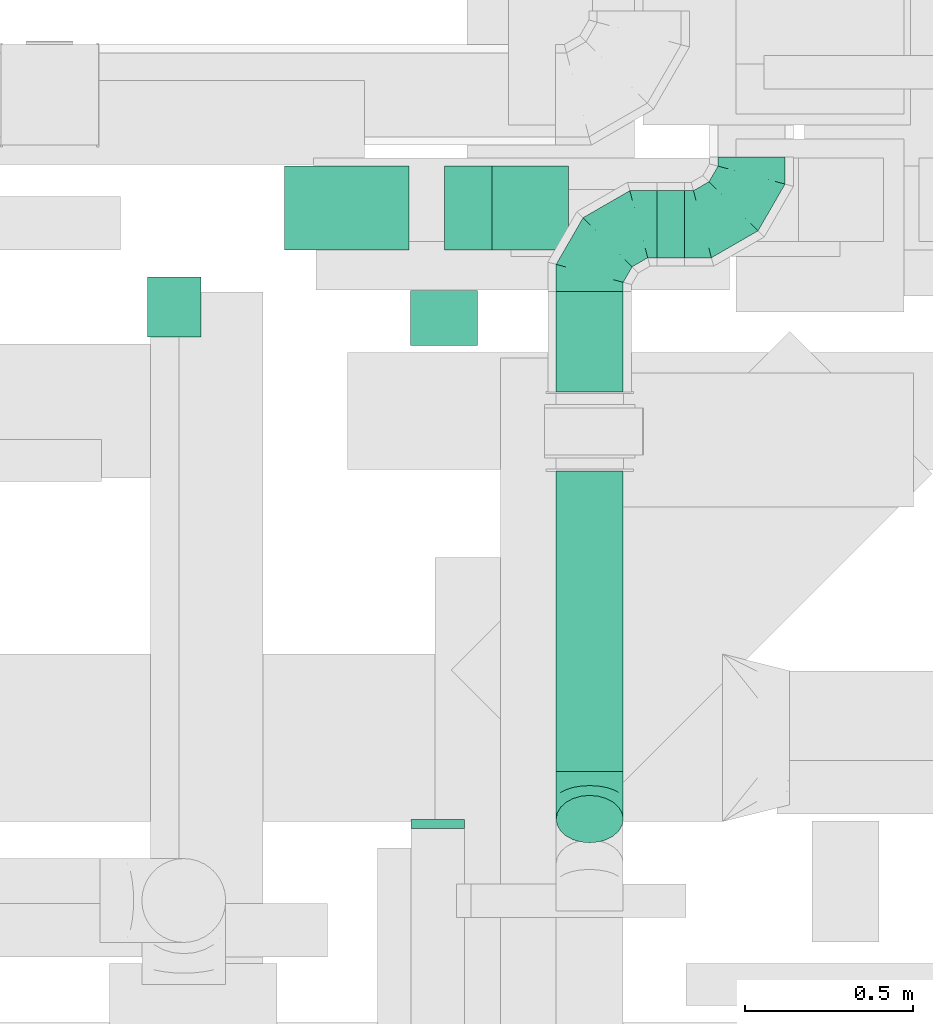
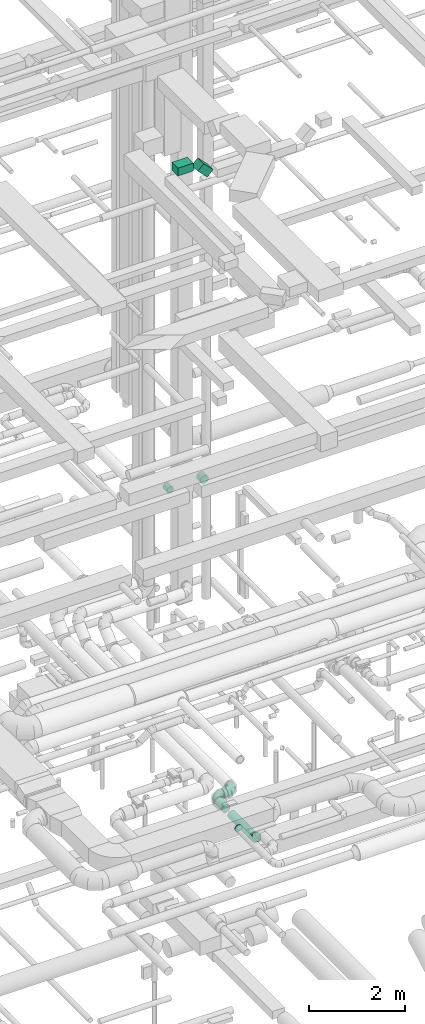
# One storey, part 165 of 337: 7 flow segments, 4 flow fittings.
"""IFC2X3 building model written with IfcOpenShell, lengths in millimetres."""

import ifcopenshell
import ifcopenshell.guid

model = None  # the IFC model being written
_history = None  # IfcOwnerHistory: only IFC2X3 demands one
_inside = {}  # id of a spatial element -> (the spatial element, [elements in it])
_under = {}  # id of a project, library or spatial element -> (it, [spatial elements below it])
_declared = {}  # id of a project -> (the project, [libraries it declares])
_typed = {}  # id of a type object -> (the type object, [elements of that type])
_made_of = {}  # id of a material, layer set ... -> (it, [elements and type objects made of it])


def new_model(schema):
    """Start an empty IFC model of exactly this schema.

    Asked for "IFC4X3", IfcOpenShell would pick the latest addendum, in which some entities
    have other attributes; the version numbers below select the first issue.
    IFC2X3 requires an IfcOwnerHistory on every rooted entity: one is made here for all.
    """
    global model, _history
    if schema == "IFC4X3":
        model = ifcopenshell.file(schema_version=(4, 3, 0, 0))
    else:
        model = ifcopenshell.file(schema=schema)
    _inside.clear()
    _under.clear()
    _declared.clear()
    _typed.clear()
    _made_of.clear()
    _history = None
    if model.schema == "IFC2X3":
        org = make("IfcOrganization", Name="unknown")
        user = make(
            "IfcPersonAndOrganization",
            ThePerson=make("IfcPerson", FamilyName="unknown"),
            TheOrganization=org,
        )
        app = make(
            "IfcApplication",
            ApplicationDeveloper=org,
            Version="unknown",
            ApplicationFullName="unknown",
            ApplicationIdentifier="unknown",
        )
        _history = make(
            "IfcOwnerHistory",
            OwningUser=user,
            OwningApplication=app,
            ChangeAction="ADDED",
            CreationDate=0,
        )
    return model


def make(cls, **values):
    """One entity of the class cls with the attributes given. An attribute that is None is left unset."""
    return model.create_entity(
        cls, **{name: value for name, value in values.items() if value is not None}
    )


def entity(cls, *values):
    """Any entity or typed value of the class cls, its attributes in the order of the schema. None: left unset."""
    e = model.create_entity(cls)
    for i, value in enumerate(values):
        if value is not None:
            e[i] = value
    return e


def rooted(cls, **values):
    """An entity with a GlobalId (a new one), such as an element, a storey or a relation."""
    return make(cls, GlobalId=ifcopenshell.guid.new(), OwnerHistory=_history, **values)


def si_unit(unit_type, name, prefix=None):
    """IfcSIUnit, for example si_unit("LENGTHUNIT", "METRE", prefix="MILLI")."""
    return make("IfcSIUnit", UnitType=unit_type, Prefix=prefix, Name=name)


def converted_unit(unit_type, name, factor, base, dimensions=None, offset=None):
    """IfcConversionBasedUnit, such as the inch: factor (a typed value) times the base unit."""
    return make(
        "IfcConversionBasedUnit"
        if offset is None
        else "IfcConversionBasedUnitWithOffset",
        ConversionOffset=offset,
        Dimensions=None
        if dimensions is None
        else entity("IfcDimensionalExponents", *dimensions),
        UnitType=unit_type,
        Name=name,
        ConversionFactor=make(
            "IfcMeasureWithUnit", ValueComponent=factor, UnitComponent=base
        ),
    )


def derived_unit(unit_type, elements):
    """IfcDerivedUnit: a product of units, each with its exponent."""
    return make(
        "IfcDerivedUnit",
        Elements=[
            make("IfcDerivedUnitElement", Unit=unit, Exponent=power)
            for unit, power in elements
        ],
        UnitType=unit_type,
    )


def assignment(units):
    """IfcUnitAssignment: the units of a project."""
    return None if units is None else make("IfcUnitAssignment", Units=units)


def point(xyz):
    """IfcCartesianPoint."""
    return None if xyz is None else make("IfcCartesianPoint", Coordinates=xyz)


def direction(xyz):
    """IfcDirection."""
    return None if xyz is None else make("IfcDirection", DirectionRatios=xyz)


def frame(location, z_axis=None, x_axis=None):
    """IfcAxis2Placement3D, a coordinate frame: its origin and axes. An axis left out is left unset."""
    return make(
        "IfcAxis2Placement3D",
        Location=point(location),
        Axis=direction(z_axis),
        RefDirection=direction(x_axis),
    )


def frame_2d(location, x_axis=None):
    """IfcAxis2Placement2D, a coordinate frame in the plane: its origin and x axis."""
    return make(
        "IfcAxis2Placement2D", Location=point(location), RefDirection=direction(x_axis)
    )


def origin():
    """The frame at (0, 0, 0) with its axes left unset."""
    return frame((0.0, 0.0, 0.0))


def origin_2d_with_axis():
    """The frame at (0, 0) in the plane with the x axis (1, 0) written out."""
    return frame_2d((0.0, 0.0), x_axis=(1.0, 0.0))


def place(relative_to, where):
    """IfcLocalPlacement: puts the frame where relative to a parent placement (None: the world)."""
    return make(
        "IfcLocalPlacement", PlacementRelTo=relative_to, RelativePlacement=where
    )


def context(
    kind, dimensions, precision=None, world=None, true_north=None, identifier=None
):
    """IfcGeometricRepresentationContext, for example the 3D "Model" context."""
    return make(
        "IfcGeometricRepresentationContext",
        ContextIdentifier=identifier,
        ContextType=kind,
        CoordinateSpaceDimension=dimensions,
        Precision=precision,
        WorldCoordinateSystem=world,
        TrueNorth=true_north,
    )


def subcontext(parent, identifier, kind, view, scale=None):
    """IfcGeometricRepresentationSubContext, for example "Body" below "Model"."""
    return make(
        "IfcGeometricRepresentationSubContext",
        ContextIdentifier=identifier,
        ContextType=kind,
        ParentContext=parent,
        TargetScale=scale,
        TargetView=view,
    )


def project(units=None, contexts=None):
    """IfcProject with its units and contexts."""
    return rooted(
        "IfcProject",
        Name="project",
        RepresentationContexts=contexts,
        UnitsInContext=assignment(units),
    )


def spatial(cls, under=None, at=None, **own):
    """A site, building, storey or space (cls), placed at a placement, below another one or the project."""
    s = rooted(cls, ObjectPlacement=at, **own)
    if under is not None:
        _under.setdefault(under.id(), (under, []))[1].append(s)
    return s


def profile(cls, at=None, kind="AREA", **sizes):
    """A parametric profile (cls). Its sizes go by their IFC names, for example OverallWidth=200.0."""
    return make(cls, ProfileType=kind, Position=at, **sizes)


def rectangle(**sizes):
    """IfcRectangleProfileDef."""
    return profile("IfcRectangleProfileDef", **sizes)


def circle(**sizes):
    """IfcCircleProfileDef."""
    return profile("IfcCircleProfileDef", **sizes)


def extrude(swept, where, along, depth):
    """IfcExtrudedAreaSolid: the profile swept, set in the frame where, extruded along a direction by depth."""
    return make(
        "IfcExtrudedAreaSolid",
        SweptArea=swept,
        Position=where,
        ExtrudedDirection=direction(along),
        Depth=depth,
    )


def faces_of(points, faces, orient=None, outer=None):
    """IfcFace entities. A face is a list of loops; a loop is a list of indices into points, from 0.

    orient and outer hold one flag for each loop. By default every Orientation is true, the
    first loop of a face is its IfcFaceOuterBound and the others are IfcFaceBound.
    """
    made = []
    for i, loops in enumerate(faces):
        bounds = []
        for j, loop in enumerate(loops):
            is_outer = j == 0 if outer is None else outer[i][j]
            bounds.append(
                make(
                    "IfcFaceOuterBound" if is_outer else "IfcFaceBound",
                    Bound=make("IfcPolyLoop", Polygon=[points[k] for k in loop]),
                    Orientation=True if orient is None else orient[i][j],
                )
            )
        made.append(make("IfcFace", Bounds=bounds))
    return made


def faceted_brep(points, faces, orient=None, outer=None, voids=None):
    """IfcFacetedBrep: a solid bounded by flat faces; with voids (closed shells), ...WithVoids."""
    shared = [point(p) for p in points]
    hull = make("IfcClosedShell", CfsFaces=faces_of(shared, faces, orient, outer))
    if voids is None:
        return make("IfcFacetedBrep", Outer=hull)
    return make(
        "IfcFacetedBrepWithVoids",
        Outer=hull,
        Voids=[
            make(cls, CfsFaces=faces_of(shared, fs, o, b)) for cls, fs, o, b in voids
        ],
    )


def shape(context_of_items, identifier, shape_type, items):
    """IfcShapeRepresentation: the items that make up one representation, for example the "Body"."""
    return make(
        "IfcShapeRepresentation",
        ContextOfItems=context_of_items,
        RepresentationIdentifier=identifier,
        RepresentationType=shape_type,
        Items=items,
    )


def source(mapping_origin, context_of_items, identifier, shape_type, items):
    """IfcRepresentationMap: a shape defined once, which mapped items show again and again."""
    return make(
        "IfcRepresentationMap",
        MappingOrigin=mapping_origin,
        MappedRepresentation=shape(context_of_items, identifier, shape_type, items),
    )


def transform(
    local_origin,
    x_axis=None,
    y_axis=None,
    z_axis=None,
    scale=None,
    scale2=None,
    scale3=None,
    uniform=True,
):
    """IfcCartesianTransformationOperator3D, or its non-uniform kind. x_axis, y_axis, z_axis: its Axis1, 2, 3."""
    if uniform:
        return make(
            "IfcCartesianTransformationOperator3D",
            Axis1=direction(x_axis),
            Axis2=direction(y_axis),
            LocalOrigin=point(local_origin),
            Scale=scale,
            Axis3=direction(z_axis),
        )
    return make(
        "IfcCartesianTransformationOperator3DnonUniform",
        Axis1=direction(x_axis),
        Axis2=direction(y_axis),
        LocalOrigin=point(local_origin),
        Scale=scale,
        Axis3=direction(z_axis),
        Scale2=scale2,
        Scale3=scale3,
    )


def mapped(mapping_source, mapping_target):
    """IfcMappedItem: shows the shape of a source again, moved by a transform."""
    return make(
        "IfcMappedItem", MappingSource=mapping_source, MappingTarget=mapping_target
    )


def material(Name=None, Category=None):
    """IfcMaterial."""
    return make("IfcMaterial", Name=Name, Category=Category)


def made_of(thing, what):
    """Note that an element or type object is made of a material, layer set ...; save() writes the relation."""
    if what is not None:
        _made_of.setdefault(what.id(), (what, []))[1].append(thing)
    return thing


def type_object(cls, material=None, **own):
    """A type object (cls), such as IfcWallType, which elements share."""
    return made_of(rooted(cls, **own), material)


def type_shapes(of_type, sources):
    """Give a type object the sources (RepresentationMaps) that its elements show as mapped items."""
    of_type.RepresentationMaps = sources


def element(
    cls,
    number,
    at=None,
    inside=None,
    cuts=None,
    type_object=None,
    material=None,
    context=None,
    identifier="Body",
    shape_type=None,
    held_by="IfcProductDefinitionShape",
    body=None,
    shapes=None,
    **own,
):
    """One element of the class cls, such as IfcWall. Its Tag is "e" and its number.

    at: its placement. inside: the storey or other place that contains it. cuts: it is an
    opening in that element (IfcRelVoidsElement). A single representation is given by context,
    identifier, shape_type and body (its items); several are given by shapes. held_by: the class
    of the entity that holds the representations. save() writes the other relations.
    """
    e = rooted(cls, Tag="e%d" % number, ObjectPlacement=at, **own)
    if body is not None:
        shapes = [shape(context, identifier, shape_type, body)]
    if shapes is not None:
        e.Representation = make(held_by, Representations=shapes)
    if inside is not None:
        _inside.setdefault(inside.id(), (inside, []))[1].append(e)
    if cuts is not None:
        rooted(
            "IfcRelVoidsElement", RelatingBuildingElement=cuts, RelatedOpeningElement=e
        )
    if type_object is not None:
        _typed.setdefault(type_object.id(), (type_object, []))[1].append(e)
    return made_of(e, material)


def aggregate(whole, parts):
    """IfcRelAggregates: a whole, such as a stair, and the parts it consists of."""
    return rooted("IfcRelAggregates", RelatingObject=whole, RelatedObjects=parts)


def save(model, path):
    """Write the relations noted so far, then the file.

    IfcRelAggregates (storeys below a building ...), IfcRelContainedInSpatialStructure (elements
    in a storey), IfcRelDefinesByType, IfcRelAssociatesMaterial and IfcRelDeclares: one each for
    every whole, place, type object, material and project.
    """
    for whole, parts in _under.values():
        aggregate(whole, parts)
    for where, things in _inside.values():
        rooted(
            "IfcRelContainedInSpatialStructure",
            RelatedElements=things,
            RelatingStructure=where,
        )
    for kind, things in _typed.values():
        rooted("IfcRelDefinesByType", RelatedObjects=things, RelatingType=kind)
    for what, things in _made_of.values():
        rooted("IfcRelAssociatesMaterial", RelatedObjects=things, RelatingMaterial=what)
    for by, libraries in _declared.values():
        rooted("IfcRelDeclares", RelatingContext=by, RelatedDefinitions=libraries)
    model.write(path)


model = new_model("IFC2X3")

# Units and contexts
model_context = context("Model", 3, precision=0.01, world=origin(), true_north=direction((6.12303176911189e-17, 1.0)))
body_context = subcontext(model_context, "Body", "Model", "MODEL_VIEW")
ifc_project = project(units=[si_unit("LENGTHUNIT", "METRE", prefix="MILLI"), si_unit("AREAUNIT", "SQUARE_METRE"), si_unit("VOLUMEUNIT", "CUBIC_METRE"), converted_unit("PLANEANGLEUNIT", "DEGREE", entity("IfcRatioMeasure", 0.0174532925199433), si_unit("PLANEANGLEUNIT", "RADIAN"), dimensions=[0, 0, 0, 0, 0, 0, 0]), si_unit("MASSUNIT", "GRAM", prefix="KILO"), derived_unit("MASSDENSITYUNIT", [(si_unit("MASSUNIT", "GRAM", prefix="KILO"), 1), (si_unit("LENGTHUNIT", "METRE"), -3)]), derived_unit("MOMENTOFINERTIAUNIT", [(si_unit("LENGTHUNIT", "METRE"), 4)]), si_unit("TIMEUNIT", "SECOND"), si_unit("FREQUENCYUNIT", "HERTZ"), si_unit("THERMODYNAMICTEMPERATUREUNIT", "DEGREE_CELSIUS"), derived_unit("THERMALTRANSMITTANCEUNIT", [(si_unit("MASSUNIT", "GRAM", prefix="KILO"), 1), (si_unit("THERMODYNAMICTEMPERATUREUNIT", "KELVIN"), -1), (si_unit("TIMEUNIT", "SECOND"), -3)]), derived_unit("VOLUMETRICFLOWRATEUNIT", [(si_unit("LENGTHUNIT", "METRE"), 3), (si_unit("TIMEUNIT", "SECOND"), -1)]), derived_unit("MASSFLOWRATEUNIT", [(si_unit("MASSUNIT", "GRAM", prefix="KILO"), 1), (si_unit("TIMEUNIT", "SECOND"), -1)]), derived_unit("ROTATIONALFREQUENCYUNIT", [(si_unit("TIMEUNIT", "SECOND"), -1)]), si_unit("ELECTRICCURRENTUNIT", "AMPERE"), si_unit("ELECTRICVOLTAGEUNIT", "VOLT"), si_unit("POWERUNIT", "WATT"), si_unit("FORCEUNIT", "NEWTON", prefix="KILO"), si_unit("ILLUMINANCEUNIT", "LUX"), si_unit("LUMINOUSFLUXUNIT", "LUMEN"), si_unit("LUMINOUSINTENSITYUNIT", "CANDELA"), derived_unit("USERDEFINED", [(si_unit("MASSUNIT", "GRAM", prefix="KILO"), -1), (si_unit("LENGTHUNIT", "METRE"), -2), (si_unit("TIMEUNIT", "SECOND"), 3), (si_unit("LUMINOUSFLUXUNIT", "LUMEN"), 1)]), derived_unit("LINEARVELOCITYUNIT", [(si_unit("LENGTHUNIT", "METRE"), 1), (si_unit("TIMEUNIT", "SECOND"), -1)]), si_unit("PRESSUREUNIT", "PASCAL"), derived_unit("USERDEFINED", [(si_unit("LENGTHUNIT", "METRE"), -2), (si_unit("MASSUNIT", "GRAM", prefix="KILO"), 1), (si_unit("TIMEUNIT", "SECOND"), -2)]), derived_unit("LINEARFORCEUNIT", [(si_unit("MASSUNIT", "GRAM", prefix="KILO"), 1), (si_unit("LENGTHUNIT", "METRE"), 1), (si_unit("TIMEUNIT", "SECOND"), -2), (si_unit("LENGTHUNIT", "METRE"), -1)]), derived_unit("PLANARFORCEUNIT", [(si_unit("MASSUNIT", "GRAM", prefix="KILO"), 1), (si_unit("LENGTHUNIT", "METRE"), 1), (si_unit("TIMEUNIT", "SECOND"), -2), (si_unit("LENGTHUNIT", "METRE"), -2)])], contexts=[model_context])

# Site, building, storey
site_placement = place(None, origin())
site = spatial("IfcSite", under=ifc_project, at=site_placement, CompositionType="ELEMENT")
building_placement = place(site_placement, origin())
building = spatial("IfcBuilding", under=site, at=building_placement, CompositionType="ELEMENT")
storey_placement = place(building_placement, origin())
storey = spatial("IfcBuildingStorey", under=building, at=storey_placement, CompositionType="ELEMENT", Elevation=0.0)

# Flow segments
duct_segment_type_1 = type_object("IfcDuctSegmentType", PredefinedType="NOTDEFINED")
flow_segment_1_placement = place(storey_placement, frame((48670.22, 5600.81, 19075.0)))
element("IfcFlowSegment", 1, at=flow_segment_1_placement, inside=storey, type_object=duct_segment_type_1, context=body_context, shape_type="SweptSolid", body=[
    extrude(rectangle(XDim=371.446609406722, YDim=249.999999999999, at=origin_2d_with_axis()), frame((185.72, 125.0, 0.0)), (0.0, 0.0, 1.0), 200.000000000002),
])
flow_segment_2_placement = place(storey_placement, frame((49147.73, 5600.81, 18803.1)))
element("IfcFlowSegment", 2, at=flow_segment_2_placement, inside=storey, type_object=duct_segment_type_1, context=body_context, shape_type="SweptSolid", body=[
    extrude(rectangle(XDim=199.99999999999, YDim=249.999999999999, at=frame_2d((0.0, 0.0), x_axis=(0.0, 1.0))), frame((298.68, 125.0, 70.71), z_axis=(-0.707106781186488, 0.0, 0.707106781186607), x_axis=(0.0, -1.0, 0.0)), (0.0, 0.0, 1.0), 322.390693496514),
])
duct_segment_type_2 = type_object("IfcDuctSegmentType", PredefinedType="NOTDEFINED")
flow_segment_3_placement = place(storey_placement, frame((48259.71, 5340.54, 11318.4)))
element("IfcFlowSegment", 3, at=flow_segment_3_placement, inside=storey, type_object=duct_segment_type_2, context=body_context, shape_type="SweptSolid", body=[
    extrude(circle(Radius=80.0, at=origin_2d_with_axis()), frame((81.6, 0.0, 81.6), z_axis=(0.0, 1.0, 0.0), x_axis=(1.0, 0.0, 0.0)), (0.0, 0.0, 1.0), 179.999999999972),
])
flow_segment_4_placement = place(storey_placement, frame((49044.22, 5315.54, 11298.4)))
element("IfcFlowSegment", 4, at=flow_segment_4_placement, inside=storey, type_object=duct_segment_type_2, context=body_context, shape_type="SweptSolid", body=[
    extrude(circle(Radius=100.0, at=origin_2d_with_axis()), frame((101.6, 0.0, 101.6), z_axis=(0.0, 1.0, 0.0), x_axis=(-1.0, 0.0, 0.0)), (0.0, 0.0, 1.0), 165.000000000081),
])
flow_segment_5_placement = place(storey_placement, frame((49478.4, 4045.27, 2898.4)))
element("IfcFlowSegment", 5, at=flow_segment_5_placement, inside=storey, type_object=duct_segment_type_2, context=body_context, shape_type="SweptSolid", body=[
    extrude(circle(Radius=100.0, at=origin_2d_with_axis()), frame((101.6, 0.0, 101.6), z_axis=(0.0, 1.0, 0.0), x_axis=(-1.0, 0.0, 0.0)), (0.0, 0.0, 1.0), 897.157287525386),
])
flow_segment_6_placement = place(storey_placement, frame((49478.4, 5177.42, 2898.4)))
element("IfcFlowSegment", 6, at=flow_segment_6_placement, inside=storey, type_object=duct_segment_type_2, context=body_context, shape_type="SweptSolid", body=[
    extrude(circle(Radius=100.0, at=origin_2d_with_axis()), frame((101.6, 0.0, 101.6), z_axis=(0.0, 1.0, 0.0), x_axis=(1.0, 0.0, 0.0)), (0.0, 0.0, 1.0), 300.000000000022),
])
flow_segment_7_placement = place(storey_placement, frame((49780.0, 5575.83, 2898.4)))
element("IfcFlowSegment", 7, at=flow_segment_7_placement, inside=storey, type_object=duct_segment_type_2, context=body_context, shape_type="SweptSolid", body=[
    extrude(circle(Radius=100.0, at=origin_2d_with_axis()), frame((0.0, 101.6, 101.6), z_axis=(1.0, 0.0, 0.0), x_axis=(0.0, 1.0, 0.0)), (0.0, 0.0, 1.0), 82.5410791304115),
])

# Flow fittings
ifc_material = material()
duct_fitting_type_1 = type_object("IfcDuctFittingType", PredefinedType="NOTDEFINED", material=ifc_material)
shared_shape_1 = source(origin(), body_context, "Body", "Brep", [
    faceted_brep([(-200.0, 0.0, -100.0), (-200.0, -25.88, -96.59), (-200.0, -50.0, -86.6), (-200.0, -70.71, -70.71), (-200.0, -86.6, -50.0), (-200.0, -96.59, -25.88), (-200.0, -100.0, 0.0), (-200.0, -96.59, 25.88), (-200.0, -86.6, 50.0), (-200.0, -70.71, 70.71), (-200.0, -50.0, 86.6), (-200.0, -25.88, 96.59), (-200.0, 0.0, 100.0), (-200.0, 25.88, 96.59), (-200.0, 50.0, 86.6), (-200.0, 70.71, 70.71), (-200.0, 86.6, 50.0), (-200.0, 96.59, 25.88), (-200.0, 100.0, 0.0), (-200.0, 96.59, -25.88), (-200.0, 86.6, -50.0), (-200.0, 70.71, -70.71), (-200.0, 50.0, -86.6), (-200.0, 25.88, -96.59), (-153.35, 25.88, 96.59), (-159.81, 50.0, 86.6), (-146.41, 0.0, 100.0), (-165.36, 70.71, 70.71), (-172.29, 96.59, 25.88), (-173.21, 100.0, 0.0), (-169.62, 86.6, 50.0), (-169.62, 86.6, -50.0), (-165.36, 70.71, -70.71), (-172.29, 96.59, -25.88), (-153.35, 25.88, -96.59), (-146.41, 0.0, -100.0), (-159.81, 50.0, -86.6), (-139.48, -25.88, -96.59), (-133.01, -50.0, -86.6), (-127.46, -70.71, -70.71), (-123.21, -86.6, -50.0), (-120.53, -96.59, -25.88), (-119.62, -100.0, 0.0), (-120.53, -96.59, 25.88), (-123.21, -86.6, 50.0), (-127.46, -70.71, 70.71), (-133.01, -50.0, 86.6), (-139.48, -25.88, 96.59), (-72.54, 72.54, 96.59), (-90.19, 90.19, 86.6), (-53.59, 53.59, 100.0), (-105.35, 105.35, 70.71), (-116.99, 116.99, 50.0), (-124.3, 124.3, 25.88), (-126.79, 126.79, 0.0), (-124.3, 124.3, -25.88), (-116.99, 116.99, -50.0), (-105.35, 105.35, -70.71), (-72.54, 72.54, -96.59), (-53.59, 53.59, -100.0), (-90.19, 90.19, -86.6), (-34.64, 34.64, -96.59), (-16.99, 16.99, -86.6), (-1.83, 1.83, -70.71), (9.81, -9.81, -50.0), (17.12, -17.12, -25.88), (19.62, -19.62, 0.0), (17.12, -17.12, 25.88), (9.81, -9.81, 50.0), (-1.83, 1.83, 70.71), (-16.99, 16.99, 86.6), (-34.64, 34.64, 96.59), (-25.88, 153.35, 96.59), (-50.0, 159.81, 86.6), (0.0, 146.41, 100.0), (-70.71, 165.36, 70.71), (-86.6, 169.62, 50.0), (-96.59, 172.29, 25.88), (-100.0, 173.21, 0.0), (-96.59, 172.29, -25.88), (-86.6, 169.62, -50.0), (-70.71, 165.36, -70.71), (-25.88, 153.35, -96.59), (0.0, 146.41, -100.0), (-50.0, 159.81, -86.6), (25.88, 139.48, -96.59), (50.0, 133.01, -86.6), (70.71, 127.46, -70.71), (86.6, 123.21, -50.0), (96.59, 120.53, -25.88), (100.0, 119.62, 0.0), (96.59, 120.53, 25.88), (86.6, 123.21, 50.0), (70.71, 127.46, 70.71), (50.0, 133.01, 86.6), (25.88, 139.48, 96.59), (-25.88, 200.0, -96.59), (-50.0, 200.0, -86.6), (-70.71, 200.0, -70.71), (-86.6, 200.0, -50.0), (-96.59, 200.0, -25.88), (-100.0, 200.0, 0.0), (-96.59, 200.0, 25.88), (-86.6, 200.0, 50.0), (-70.71, 200.0, 70.71), (-50.0, 200.0, 86.6), (-25.88, 200.0, 96.59), (0.0, 200.0, 100.0), (25.88, 200.0, 96.59), (50.0, 200.0, 86.6), (70.71, 200.0, 70.71), (86.6, 200.0, 50.0), (96.59, 200.0, 25.88), (100.0, 200.0, 0.0), (96.59, 200.0, -25.88), (86.6, 200.0, -50.0), (70.71, 200.0, -70.71), (50.0, 200.0, -86.6), (25.88, 200.0, -96.59), (0.0, 200.0, -100.0)], [[[0, 1, 2, 3, 4, 5, 6, 7, 8, 9, 10, 11, 12, 13, 14, 15, 16, 17, 18, 19, 20, 21, 22, 23]], [[24, 25, 14, 13]], [[26, 24, 13, 12]], [[14, 25, 27, 15]], [[28, 29, 18, 17]], [[30, 28, 17, 16]], [[15, 27, 30, 16]], [[20, 31, 32, 21]], [[33, 31, 20, 19]], [[18, 29, 33, 19]], [[34, 35, 0, 23]], [[36, 34, 23, 22]], [[32, 36, 22, 21]], [[1, 0, 35, 37]], [[2, 1, 37, 38]], [[38, 39, 3, 2]], [[5, 4, 40, 41]], [[6, 5, 41, 42]], [[39, 40, 4, 3]], [[6, 42, 43, 7]], [[7, 43, 44, 8]], [[8, 44, 45, 9]], [[9, 45, 46, 10]], [[10, 46, 47, 11]], [[26, 12, 11, 47]], [[48, 49, 25, 24]], [[50, 48, 24, 26]], [[27, 25, 49, 51]], [[52, 53, 28, 30]], [[51, 52, 30, 27]], [[29, 28, 53, 54]], [[55, 56, 31, 33]], [[54, 55, 33, 29]], [[32, 31, 56, 57]], [[58, 59, 35, 34]], [[60, 58, 34, 36]], [[57, 60, 36, 32]], [[37, 35, 59, 61]], [[38, 37, 61, 62]], [[39, 38, 62, 63]], [[41, 40, 64, 65]], [[42, 41, 65, 66]], [[63, 64, 40, 39]], [[43, 42, 66, 67]], [[44, 43, 67, 68]], [[68, 69, 45, 44]], [[46, 45, 69, 70]], [[47, 46, 70, 71]], [[26, 47, 71, 50]], [[72, 73, 49, 48]], [[74, 72, 48, 50]], [[51, 49, 73, 75]], [[76, 77, 53, 52]], [[75, 76, 52, 51]], [[54, 53, 77, 78]], [[79, 80, 56, 55]], [[78, 79, 55, 54]], [[57, 56, 80, 81]], [[82, 83, 59, 58]], [[84, 82, 58, 60]], [[81, 84, 60, 57]], [[61, 59, 83, 85]], [[62, 61, 85, 86]], [[63, 62, 86, 87]], [[65, 64, 88, 89]], [[66, 65, 89, 90]], [[87, 88, 64, 63]], [[67, 66, 90, 91]], [[68, 67, 91, 92]], [[92, 93, 69, 68]], [[70, 69, 93, 94]], [[71, 70, 94, 95]], [[50, 71, 95, 74]], [[96, 97, 98, 99, 100, 101, 102, 103, 104, 105, 106, 107, 108, 109, 110, 111, 112, 113, 114, 115, 116, 117, 118, 119]], [[72, 74, 107, 106]], [[73, 72, 106, 105]], [[75, 73, 105, 104]], [[102, 101, 78, 77]], [[103, 102, 77, 76]], [[75, 104, 103, 76]], [[78, 101, 100, 79]], [[79, 100, 99, 80]], [[80, 99, 98, 81]], [[84, 97, 96, 82]], [[82, 96, 119, 83]], [[84, 81, 98, 97]], [[118, 117, 86, 85]], [[119, 118, 85, 83]], [[116, 87, 86, 117]], [[88, 115, 114, 89]], [[89, 114, 113, 90]], [[115, 88, 87, 116]], [[91, 90, 113, 112]], [[92, 91, 112, 111]], [[111, 110, 93, 92]], [[95, 94, 109, 108]], [[74, 95, 108, 107]], [[110, 109, 94, 93]]]),
])
type_shapes(duct_fitting_type_1, [shared_shape_1])
flow_fitting_1_placement = place(storey_placement, frame((49580.0, 5677.42, 3000.0), z_axis=(0.0, 0.0, 1.0), x_axis=(-1.0, 0.0, 0.0)))
element("IfcFlowFitting", 8, at=flow_fitting_1_placement, inside=storey, type_object=duct_fitting_type_1, material=ifc_material, context=body_context, shape_type="MappedRepresentation", body=[
    mapped(shared_shape_1, transform((0.0, 0.0, 0.0), scale=1.0)),
])
flow_fitting_2_placement = place(storey_placement, frame((50062.54, 5677.42, 3000.0)))
element("IfcFlowFitting", 9, at=flow_fitting_2_placement, inside=storey, type_object=duct_fitting_type_1, material=ifc_material, context=body_context, shape_type="MappedRepresentation", body=[
    mapped(shared_shape_1, transform((0.0, 0.0, 0.0), scale=1.0)),
])
duct_fitting_type_2 = type_object("IfcDuctFittingType", PredefinedType="NOTDEFINED", material=ifc_material)
shared_shape_2 = source(origin(), body_context, "Body", "Brep", [
    faceted_brep([(-82.84, 0.0, -100.0), (-82.84, -25.88, -96.59), (-82.84, -50.0, -86.6), (-82.84, -70.71, -70.71), (-82.84, -86.6, -50.0), (-82.84, -96.59, -25.88), (-82.84, -100.0, 0.0), (-82.84, -96.59, 25.88), (-82.84, -86.6, 50.0), (-82.84, -70.71, 70.71), (-82.84, -50.0, 86.6), (-82.84, -25.88, 96.59), (-82.84, 0.0, 100.0), (-82.84, 25.88, 96.59), (-82.84, 50.0, 86.6), (-82.84, 70.71, 70.71), (-82.84, 86.6, 50.0), (-82.84, 96.59, 25.88), (-82.84, 100.0, 0.0), (-82.84, 96.59, -25.88), (-82.84, 86.6, -50.0), (-82.84, 70.71, -70.71), (-82.84, 50.0, -86.6), (-82.84, 25.88, -96.59), (-10.72, 25.88, 96.59), (-20.71, 50.0, 86.6), (0.0, 0.0, 100.0), (-29.29, 70.71, 70.71), (-35.87, 86.6, 50.0), (-40.01, 96.59, 25.88), (-41.42, 100.0, 0.0), (-40.01, 96.59, -25.88), (-35.87, 86.6, -50.0), (-29.29, 70.71, -70.71), (-10.72, 25.88, -96.59), (0.0, 0.0, -100.0), (-20.71, 50.0, -86.6), (10.72, -25.88, -96.59), (20.71, -50.0, -86.6), (29.29, -70.71, -70.71), (35.87, -86.6, -50.0), (40.01, -96.59, -25.88), (41.42, -100.0, 0.0), (40.01, -96.59, 25.88), (35.87, -86.6, 50.0), (29.29, -70.71, 70.71), (20.71, -50.0, 86.6), (10.72, -25.88, 96.59), (58.58, 58.58, 100.0), (40.28, 76.88, 96.59), (23.22, 93.93, 86.6), (8.58, 108.58, 70.71), (-2.66, 119.82, 50.0), (-9.72, 126.88, 25.88), (-12.13, 129.29, 0.0), (-9.72, 126.88, -25.88), (-2.66, 119.82, -50.0), (8.58, 108.58, -70.71), (23.22, 93.93, -86.6), (40.28, 76.88, -96.59), (58.58, 58.58, -100.0), (76.88, 40.28, -96.59), (93.93, 23.22, -86.6), (108.58, 8.58, -70.71), (119.82, -2.66, -50.0), (126.88, -9.72, -25.88), (129.29, -12.13, 0.0), (126.88, -9.72, 25.88), (119.82, -2.66, 50.0), (108.58, 8.58, 70.71), (93.93, 23.22, 86.6), (76.88, 40.28, 96.59)], [[[0, 1, 2, 3, 4, 5, 6, 7, 8, 9, 10, 11, 12, 13, 14, 15, 16, 17, 18, 19, 20, 21, 22, 23]], [[24, 25, 14, 13]], [[26, 24, 13, 12]], [[14, 25, 27, 15]], [[28, 29, 17, 16]], [[28, 16, 15, 27]], [[30, 18, 17, 29]], [[31, 32, 20, 19]], [[30, 31, 19, 18]], [[32, 33, 21, 20]], [[34, 35, 0, 23]], [[36, 34, 23, 22]], [[33, 36, 22, 21]], [[1, 0, 35, 37]], [[2, 1, 37, 38]], [[38, 39, 3, 2]], [[5, 4, 40, 41]], [[6, 5, 41, 42]], [[39, 40, 4, 3]], [[6, 42, 43, 7]], [[7, 43, 44, 8]], [[8, 44, 45, 9]], [[9, 45, 46, 10]], [[10, 46, 47, 11]], [[26, 12, 11, 47]], [[24, 26, 48, 49]], [[25, 24, 49, 50]], [[27, 25, 50, 51]], [[29, 28, 52, 53]], [[30, 29, 53, 54]], [[51, 52, 28, 27]], [[30, 54, 55, 31]], [[31, 55, 56, 32]], [[57, 33, 32, 56]], [[36, 58, 59, 34]], [[34, 59, 60, 35]], [[58, 36, 33, 57]], [[35, 60, 61, 37]], [[37, 61, 62, 38]], [[63, 39, 38, 62]], [[40, 64, 65, 41]], [[41, 65, 66, 42]], [[64, 40, 39, 63]], [[43, 42, 66, 67]], [[44, 43, 67, 68]], [[68, 69, 45, 44]], [[47, 46, 70, 71]], [[26, 47, 71, 48]], [[69, 70, 46, 45]], [[59, 58, 57, 56, 55, 54, 53, 52, 51, 50, 49, 48, 71, 70, 69, 68, 67, 66, 65, 64, 63, 62, 61, 60]]]),
])
type_shapes(duct_fitting_type_2, [shared_shape_2])
flow_fitting_3_placement = place(storey_placement, frame((49580.0, 3962.42, 3000.0), z_axis=(-1.0, 0.0, 0.0), x_axis=(0.0, -1.0, 0.0)))
element("IfcFlowFitting", 10, at=flow_fitting_3_placement, inside=storey, type_object=duct_fitting_type_2, material=ifc_material, context=body_context, shape_type="MappedRepresentation", body=[
    mapped(shared_shape_2, transform((0.0, 0.0, 0.0), scale=1.0)),
])
duct_fitting_type_3 = type_object("IfcDuctFittingType", PredefinedType="NOTDEFINED", material=ifc_material)
shared_shape_3 = source(origin(), body_context, "Body", "Brep", [
    faceted_brep([(20.0, 20.71, -77.27), (20.0, 40.0, -69.28), (20.0, 56.57, -56.57), (20.0, 69.28, -40.0), (20.0, 77.27, -20.71), (20.0, 80.0, 0.0), (20.0, 77.27, 20.71), (20.0, 69.28, 40.0), (20.0, 56.57, 56.57), (20.0, 40.0, 69.28), (20.0, 20.71, 77.27), (20.0, 0.0, 80.0), (20.0, -20.71, 77.27), (20.0, -40.0, 69.28), (20.0, -56.57, 56.57), (20.0, -69.28, 40.0), (20.0, -77.27, 20.71), (20.0, -80.0, 0.0), (20.0, -77.27, -20.71), (20.0, -69.28, -40.0), (20.0, -56.57, -56.57), (20.0, -40.0, -69.28), (20.0, -20.71, -77.27), (20.0, 0.0, -80.0), (0.0, 0.0, 80.0), (0.0, 20.71, 77.27), (-6.1, 20.71, 77.27), (-6.1, 0.0, 80.0), (0.0, 40.0, 69.28), (-6.1, 40.0, 69.28), (0.0, 56.57, 56.57), (-6.1, 56.57, 56.57), (0.0, 69.28, 40.0), (0.0, 77.27, 20.71), (-6.1, 77.27, 20.71), (-6.1, 69.28, 40.0), (0.0, 80.0, 0.0), (-6.1, 80.0, 0.0), (0.0, 77.27, -20.71), (-6.1, 77.27, -20.71), (0.0, 69.28, -40.0), (-6.1, 69.28, -40.0), (0.0, 56.57, -56.57), (-6.1, 56.57, -56.57), (0.0, 40.0, -69.28), (0.0, 20.71, -77.27), (-6.1, 20.71, -77.27), (-6.1, 40.0, -69.28), (0.0, 0.0, -80.0), (-6.1, 0.0, -80.0), (0.0, -20.71, -77.27), (-6.1, -20.71, -77.27), (0.0, -40.0, -69.28), (-6.1, -40.0, -69.28), (0.0, -56.57, -56.57), (-6.1, -56.57, -56.57), (0.0, -69.28, -40.0), (0.0, -77.27, -20.71), (-6.1, -77.27, -20.71), (-6.1, -69.28, -40.0), (0.0, -80.0, 0.0), (-6.1, -80.0, 0.0), (0.0, -77.27, 20.71), (-6.1, -77.27, 20.71), (0.0, -69.28, 40.0), (-6.1, -69.28, 40.0), (0.0, -56.57, 56.57), (-6.1, -56.57, 56.57), (0.0, -40.0, 69.28), (0.0, -20.71, 77.27), (-6.1, -20.71, 77.27), (-6.1, -40.0, 69.28)], [[[0, 1, 2, 3, 4, 5, 6, 7, 8, 9, 10, 11, 12, 13, 14, 15, 16, 17, 18, 19, 20, 21, 22, 23]], [[24, 11, 10, 25, 26, 27]], [[25, 10, 9, 28, 29, 26]], [[28, 9, 8, 30, 31, 29]], [[32, 7, 6, 33, 34, 35]], [[33, 6, 5, 36, 37, 34]], [[30, 8, 7, 32, 35, 31]], [[36, 5, 4, 38, 39, 37]], [[38, 4, 3, 40, 41, 39]], [[40, 3, 2, 42, 43, 41]], [[44, 1, 0, 45, 46, 47]], [[45, 0, 23, 48, 49, 46]], [[42, 2, 1, 44, 47, 43]], [[48, 23, 22, 50, 51, 49]], [[50, 22, 21, 52, 53, 51]], [[52, 21, 20, 54, 55, 53]], [[56, 19, 18, 57, 58, 59]], [[57, 18, 17, 60, 61, 58]], [[54, 20, 19, 56, 59, 55]], [[60, 17, 16, 62, 63, 61]], [[62, 16, 15, 64, 65, 63]], [[64, 15, 14, 66, 67, 65]], [[68, 13, 12, 69, 70, 71]], [[69, 12, 11, 24, 27, 70]], [[66, 14, 13, 68, 71, 67]], [[49, 51, 53, 55, 59, 58, 61, 63, 65, 67, 71, 70, 27, 26, 29, 31, 35, 34, 37, 39, 41, 43, 47, 46]]]),
])
type_shapes(duct_fitting_type_3, [shared_shape_3])
flow_fitting_4_placement = place(storey_placement, frame((49126.6, 3896.24, 3450.0), z_axis=(0.0, 0.0, -1.0), x_axis=(0.0, -1.0, 0.0)))
element("IfcFlowFitting", 11, at=flow_fitting_4_placement, inside=storey, type_object=duct_fitting_type_3, material=ifc_material, context=body_context, shape_type="MappedRepresentation", body=[
    mapped(shared_shape_3, transform((0.0, 0.0, 0.0), scale=1.0)),
])

save(model, "model.ifc")
